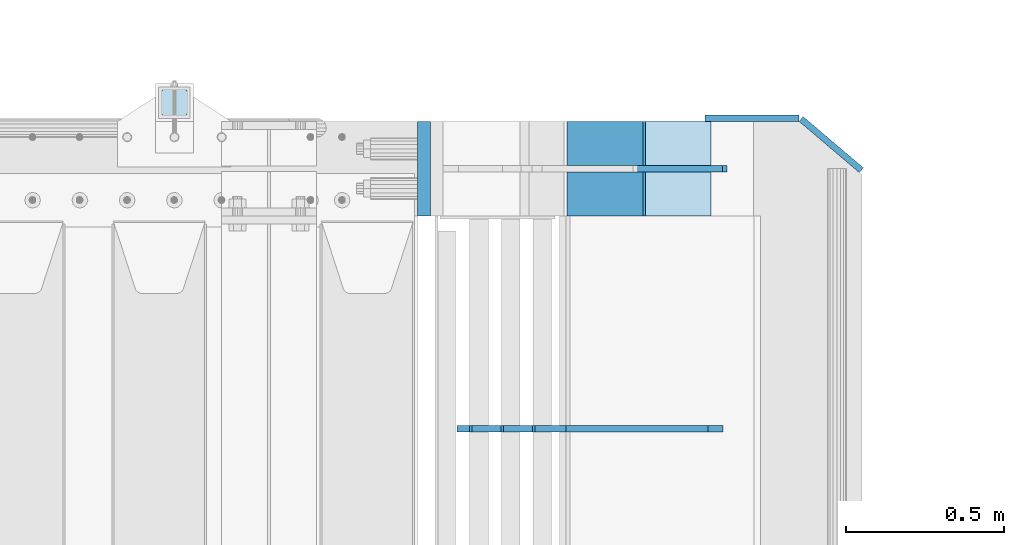
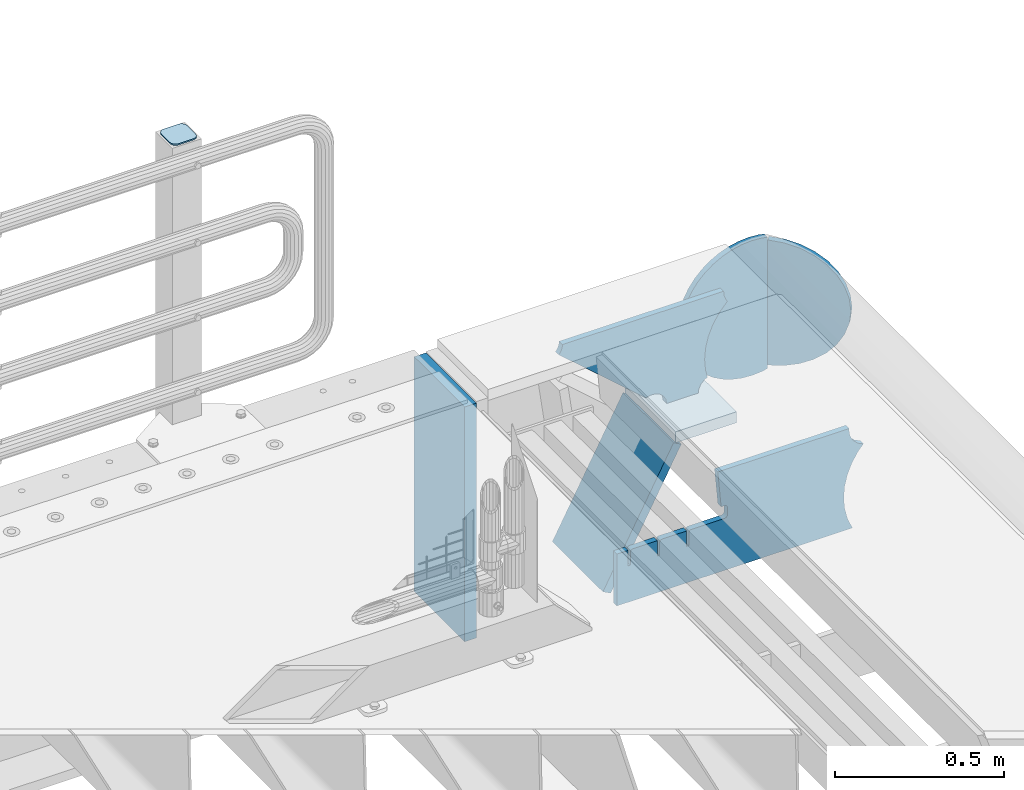
# One storey, part 227 of 242: 8 plates.
"""IFC2X3 building model written with IfcOpenShell, lengths in millimetres."""

from ifc_helpers import new_model, si_unit, frame, origin_with_axes, place, context, subcontext, project, spatial, faceted_brep, material, type_object, element, save


model = new_model("IFC2X3")

# Units and contexts
model_context = context("Model", 3, precision=1e-05, world=origin_with_axes())
body_context = subcontext(model_context, "Body", "Model", "MODEL_VIEW")
ifc_project = project(units=[si_unit("LENGTHUNIT", "METRE", prefix="MILLI"), si_unit("AREAUNIT", "SQUARE_METRE"), si_unit("VOLUMEUNIT", "CUBIC_METRE"), si_unit("MASSUNIT", "GRAM", prefix="KILO"), si_unit("TIMEUNIT", "SECOND"), si_unit("PLANEANGLEUNIT", "RADIAN"), si_unit("SOLIDANGLEUNIT", "STERADIAN"), si_unit("THERMODYNAMICTEMPERATUREUNIT", "DEGREE_CELSIUS"), si_unit("LUMINOUSINTENSITYUNIT", "LUMEN")], contexts=[model_context])

# Site, building, storey
site_placement = place(None, origin_with_axes())
site = spatial("IfcSite", under=ifc_project, at=site_placement, CompositionType="ELEMENT")
building_placement = place(site_placement, origin_with_axes())
building = spatial("IfcBuilding", under=site, at=building_placement, Name="Standard", CompositionType="ELEMENT")
storey_placement = place(building_placement, origin_with_axes())
storey = spatial("IfcBuildingStorey", under=building, at=storey_placement, Name="Undefined", CompositionType="ELEMENT", Elevation=0.0)

# Plates
ifc_material_1 = material(Name="STEEL/S355J2")
plate_type_1 = type_object("IfcPlateType", PredefinedType="NOTDEFINED")
plate_1_placement = place(storey_placement, frame((-22787.9999999999, -17833.9999999998, 1012.50000000001), z_axis=(0.0, 1.0, 0.0), x_axis=(-1.0, 0.0, 0.0)))
element("IfcPlate", 1, at=plate_1_placement, inside=storey, type_object=plate_type_1, material=ifc_material_1, context=body_context, shape_type="Brep", body=[
    faceted_brep([(0.0, -2.5, 19.0), (0.0, -2.5, 69.0), (0.0, 2.5, 69.0), (0.0, 2.5, 19.0), (0.476369668544066, -2.5, 73.2278977451715), (0.476369668544066, 2.5, 73.2278977451715), (1.88159150985302, -2.5, 77.2437910432345), (1.88159150985302, 2.5, 77.2437910432345), (4.14520183310742, -2.5, 80.8463062353148), (4.14520183310742, 2.5, 80.8463062353148), (7.15369376468516, -2.5, 83.8547981668926), (7.15369376468516, 2.5, 83.8547981668926), (10.7562089567655, -2.5, 86.118408490147), (10.7562089567655, 2.5, 86.118408490147), (14.7721022548285, -2.5, 87.5236303314559), (14.7721022548285, 2.5, 87.5236303314559), (19.0, -2.5, 88.0), (19.0, 2.5, 88.0), (69.0, -2.5, 88.0), (69.0, 2.5, 88.0), (73.2278977451715, -2.5, 87.5236303314559), (73.2278977451715, 2.5, 87.5236303314559), (77.2437910432345, -2.5, 86.118408490147), (77.2437910432345, 2.5, 86.118408490147), (80.8463062353148, -2.5, 83.8547981668926), (80.8463062353148, 2.5, 83.8547981668926), (83.8547981668926, -2.5, 80.8463062353148), (83.8547981668926, 2.5, 80.8463062353148), (86.118408490147, -2.5, 77.2437910432345), (86.118408490147, 2.5, 77.2437910432345), (87.5236303314559, -2.5, 73.2278977451715), (87.5236303314559, 2.5, 73.2278977451715), (88.0, -2.5, 69.0), (88.0, 2.5, 69.0), (88.0, -2.5, 19.0), (88.0, 2.5, 19.0), (87.5236303314559, -2.5, 14.7721022548285), (87.5236303314559, 2.5, 14.7721022548285), (86.118408490147, -2.5, 10.7562089567655), (86.118408490147, 2.5, 10.7562089567655), (83.8547981668926, -2.5, 7.15369376468516), (83.8547981668926, 2.5, 7.15369376468516), (80.8463062353148, -2.5, 4.14520183310742), (80.8463062353148, 2.5, 4.14520183310742), (77.2437910432345, -2.5, 1.88159150985302), (77.2437910432345, 2.5, 1.88159150985302), (73.2278977451715, -2.5, 0.476369668544066), (73.2278977451715, 2.5, 0.476369668544066), (69.0, -2.5, 0.0), (69.0, 2.5, 0.0), (19.0, -2.5, 0.0), (19.0, 2.5, 0.0), (14.7721022548285, -2.5, 0.476369668544066), (14.7721022548285, 2.5, 0.476369668544066), (10.7562089567655, -2.5, 1.88159150985302), (10.7562089567655, 2.5, 1.88159150985302), (7.15369376468516, -2.5, 4.14520183310742), (7.15369376468516, 2.5, 4.14520183310742), (4.14520183310742, -2.5, 7.15369376468516), (4.14520183310742, 2.5, 7.15369376468516), (1.88159150985302, -2.5, 10.7562089567655), (1.88159150985302, 2.5, 10.7562089567655), (0.476369668544066, -2.5, 14.7721022548285), (0.476369668544066, 2.5, 14.7721022548285)], [[[0, 1, 2, 3]], [[1, 4, 5, 2]], [[4, 6, 7, 5]], [[6, 8, 9, 7]], [[8, 10, 11, 9]], [[10, 12, 13, 11]], [[12, 14, 15, 13]], [[14, 16, 17, 15]], [[16, 18, 19, 17]], [[18, 20, 21, 19]], [[20, 22, 23, 21]], [[22, 24, 25, 23]], [[24, 26, 27, 25]], [[26, 28, 29, 27]], [[28, 30, 31, 29]], [[30, 32, 33, 31]], [[32, 34, 35, 33]], [[34, 36, 37, 35]], [[36, 38, 39, 37]], [[38, 40, 41, 39]], [[40, 42, 43, 41]], [[42, 44, 45, 43]], [[44, 46, 47, 45]], [[46, 48, 49, 47]], [[48, 50, 51, 49]], [[50, 52, 53, 51]], [[52, 54, 55, 53]], [[54, 56, 57, 55]], [[56, 58, 59, 57]], [[58, 60, 61, 59]], [[60, 62, 63, 61]], [[62, 0, 3, 63]], [[5, 7, 9, 11, 13, 15, 17, 19, 21, 23, 25, 27, 29, 31, 33, 35, 37, 39, 41, 43, 45, 47, 49, 51, 53, 55, 57, 59, 61, 63, 3, 2]], [[62, 60, 58, 56, 54, 52, 50, 48, 46, 44, 42, 40, 38, 36, 34, 32, 30, 28, 26, 24, 22, 20, 18, 16, 14, 12, 10, 8, 6, 4, 1, 0]]]),
])
ifc_material_2 = material(Name="STEEL/S355N")
plate_type_2 = type_object("IfcPlateType", PredefinedType="NOTDEFINED")
plate_2_placement = place(storey_placement, frame((-21338.0011701102, -18150.0000000008, -387.999999999302), z_axis=(1.0, 0.0, 0.0), x_axis=(0.0, 1.0, 0.0)))
element("IfcPlate", 2, at=plate_2_placement, inside=storey, type_object=plate_type_2, material=ifc_material_2, context=body_context, shape_type="Brep", body=[
    faceted_brep([(0.0, -20.0, 0.0), (3.31056071445346e-10, -20.0, 208.0), (3.31056071445346e-10, 20.0, 208.0), (0.0, 20.0, 0.0), (300.0, -20.0, 208.0), (300.0, 20.0, 208.0), (300.0, -20.0, 3.63797880709171e-12), (300.0, 20.0, 3.63797880709171e-12)], [[[0, 1, 2, 3]], [[1, 4, 5, 2]], [[4, 6, 7, 5]], [[6, 0, 3, 7]], [[5, 7, 3, 2]], [[6, 4, 1, 0]]]),
])
plate_type_3 = type_object("IfcPlateType", PredefinedType="NOTDEFINED")
plate_3_placement = place(storey_placement, frame((-21573.7531990434, -17849.999999999, -867.038754739308), z_axis=(0.469471552246176, 0.0, 0.882947598462992), x_axis=(0.0, -1.0, 0.0)))
element("IfcPlate", 3, at=plate_3_placement, inside=storey, type_object=plate_type_3, material=ifc_material_2, context=body_context, shape_type="Brep", body=[
    faceted_brep([(0.0, -15.0, 0.0), (0.0, -15.0000000000036, 515.0), (0.0, 15.0, 515.000000000002), (0.0, 15.0, 0.0), (300.0, -15.0000000000036, 515.0), (300.0, 15.0, 515.000000000002), (300.0, -15.0, 0.0), (300.0, 15.0, 0.0)], [[[0, 1, 2, 3]], [[1, 4, 5, 2]], [[4, 6, 7, 5]], [[6, 0, 3, 7]], [[5, 7, 3, 2]], [[6, 4, 1, 0]]]),
])
ifc_material_3 = material()
plate_type_4 = type_object("IfcPlateType", PredefinedType="NOTDEFINED")
plate_4_placement = place(storey_placement, frame((-22040.0, -17850.0, -875.0), z_axis=(0.0, 0.0, 1.0), x_axis=(0.0, -1.0, 0.0)))
element("IfcPlate", 4, at=plate_4_placement, inside=storey, type_object=plate_type_4, material=ifc_material_3, context=body_context, shape_type="Brep", body=[
    faceted_brep([(0.0, -20.0, 0.0), (9.5367431640625e-07, -20.0, 850.0), (9.5367431640625e-07, 20.0, 850.0), (0.0, 20.0, 0.0), (300.0, -20.0, 850.0), (300.0, 20.0, 850.0), (300.0, -20.0, 3.63797880709171e-12), (300.0, 20.0, 3.63797880709171e-12)], [[[0, 1, 2, 3]], [[1, 4, 5, 2]], [[4, 6, 7, 5]], [[6, 0, 3, 7]], [[5, 7, 3, 2]], [[6, 4, 1, 0]]]),
])
plate_type_5 = type_object("IfcPlateType", PredefinedType="NOTDEFINED")
plate_5_placement = place(storey_placement, frame((-21023.0011701102, -18000.0000000006, -29.9999999993023), z_axis=(-0.000446694000102124, 0.0, -0.99999990023223), x_axis=(-0.99999990023223, 0.0, 0.000446694000103734)))
element("IfcPlate", 5, at=plate_5_placement, inside=storey, type_object=plate_type_5, material=ifc_material_2, context=body_context, shape_type="Brep", body=[
    faceted_brep([(125.007775472979, 10.0, 291.842314882029), (131.755016800049, 10.0, 263.793234614468), (131.755016800049, -10.0, 263.793234614468), (125.007775472979, -10.0, 291.842314882029), (134.899927074479, 10.0, 224.060281342732), (134.899927074479, -10.0, 224.060281342732), (131.790514995217, 10.0, 184.324534302446), (131.790514995217, -10.0, 184.324534302446), (122.503344607205, 10.0, 145.564419461128), (122.503344607205, -10.0, 145.564419461128), (107.267096867741, 10.0, 108.734339483615), (107.267096867741, -10.0, 108.734339483615), (86.4569387623887, 10.0, 74.7411731709829), (86.4569387623887, -10.0, 74.7411731709829), (60.5852854486475, 10.0, 44.4219450946983), (60.5852854486475, -10.0, 44.4219450946983), (56.2519855253086, 10.0, 40.7176084148888), (56.2519855253086, -10.0, 40.7176084148888), (136.409234539125, -10.0, 297.721677540594), (147.386991180581, -10.0, 308.778803581017), (147.386991180581, 10.0, 308.778803581017), (136.409234539125, 10.0, 297.721677540594), (154.428166132755, -10.0, 322.678193223937), (154.428166132755, 10.0, 322.678193223937), (156.849001662973, -10.0, 338.070097995228), (156.849001662973, 10.0, 338.070097995228), (264.849004013293, -10.0, 338.118348049693), (264.849004013293, 10.0, 338.118348049693), (267.62876711955, -10.0, 321.701412969031), (267.62876711955, 10.0, 321.701412969031), (275.645118712175, -10.0, 307.107546191754), (275.645118712175, 10.0, 307.107546191754), (288.009068357209, -10.0, 295.955165748785), (288.009068357209, 10.0, 295.955165748785), (303.34948944753, -10.0, 289.481038692482), (303.34948944753, 10.0, 289.481038692482), (319.965173216922, -10.0, 288.403127172445), (319.965173216922, 10.0, 288.403127172445), (336.013487920231, -10.0, 292.840968489265), (336.013487920231, 10.0, 292.840968489265), (335.86907958984, -10.0, 293.150054931641), (335.86907958984, 10.0, 293.150054931641), (633.93705743644, -10.0, 32.8861672876964), (633.93705743644, 10.0, 32.8861672876964), (628.672097726398, -10.0, 25.6357574923157), (628.672097726398, 10.0, 25.6357574923157), (624.785781531267, -10.0, 17.5620477266101), (624.785781531267, 10.0, 17.5620477266101), (622.402919050597, -10.0, 8.92432757904925), (622.402919050597, 10.0, 8.92432757904925), (621.600036621094, -10.0, -8.74685213148041e-10), (621.600036621094, 10.0, -8.74685213148041e-10), (69.9999999999964, -10.0, -9.85096448857803e-11), (69.9999999999964, 10.0, -9.85096448857803e-11), (67.7728137216582, -10.0, 17.5170123094482), (67.7728137216582, 10.0, 17.5170123094482), (61.2329794213947, -10.0, 33.9193489203214), (61.2329794213947, 10.0, 33.9193489203214)], [[[0, 1, 2, 3]], [[4, 5, 2, 1]], [[6, 7, 5, 4]], [[8, 9, 7, 6]], [[10, 11, 9, 8]], [[12, 13, 11, 10]], [[14, 15, 13, 12]], [[16, 17, 15, 14]], [[18, 19, 20, 21]], [[19, 22, 23, 20]], [[22, 24, 25, 23]], [[24, 26, 27, 25]], [[26, 28, 29, 27]], [[28, 30, 31, 29]], [[30, 32, 33, 31]], [[32, 34, 35, 33]], [[34, 36, 37, 35]], [[36, 38, 39, 37]], [[38, 40, 41, 39]], [[40, 42, 43, 41]], [[42, 44, 45, 43]], [[44, 46, 47, 45]], [[46, 48, 49, 47]], [[48, 50, 51, 49]], [[50, 52, 53, 51]], [[52, 54, 55, 53]], [[54, 56, 57, 55]], [[12, 10, 8, 6, 4, 1, 0, 21, 20, 23, 25, 27, 29, 31, 33, 35, 37, 39, 41, 43, 45, 47, 49, 51, 53, 55, 57, 16, 14]], [[18, 21, 0, 3]], [[56, 54, 52, 50, 48, 46, 44, 42, 40, 38, 36, 34, 32, 30, 28, 26, 24, 22, 19, 18, 3, 2, 5, 7, 9, 11, 13, 15, 17]], [[57, 56, 17, 16]]]),
])
plate_type_6 = type_object("IfcPlateType", PredefinedType="NOTDEFINED")
plate_6_placement = place(storey_placement, frame((-21094.0817660324, -18825.0007171631, -374.002067436516), z_axis=(0.0, 0.0, 1.0), x_axis=(-1.0, 0.0, 0.0)))
element("IfcPlate", 6, at=plate_6_placement, inside=storey, type_object=plate_type_6, material=ifc_material_2, context=body_context, shape_type="Brep", body=[
    faceted_brep([(801.919404066546, -10.0, 188.0), (801.919404066546, 10.0, 188.0), (801.919404066546, 10.0, 132.002067436952), (801.919404066546, -10.0, 132.002067436952), (793.919404066546, 10.0, 132.002067436952), (793.919404066546, -10.0, 132.002067436952), (793.919404066546, 10.0, 180.002067436952), (793.919404066546, -10.0, 180.002067436952), (793.527856196906, 10.0, 182.474203391951), (793.527856196906, -10.0, 182.474203391951), (792.391540021545, 10.0, 184.704349455291), (792.391540021545, -10.0, 184.704349455291), (790.621686084887, 10.0, 186.474203391951), (790.621686084887, -10.0, 186.474203391951), (788.391540021545, 10.0, 187.610519567313), (788.391540021545, -10.0, 187.610519567313), (785.919404066546, -10.0, 188.002067436952), (785.919404066546, 10.0, 188.0), (841.0, -10.0, 188.0), (841.0, -10.0, 0.0), (841.0, 10.0, 0.0), (841.0, 10.0, 188.0), (33.3619566735979, -10.0, 0.0), (33.3619566735979, 10.0, 0.0), (36.2350612208174, -10.0, 4.68848050267007), (36.2350612208174, 10.0, 4.68848050267007), (51.4877592159428, -10.0, 41.5117508652783), (51.4877592159428, 10.0, 41.5117508652783), (60.792242588137, -10.0, 80.2677133162963), (60.792242588137, 10.0, 80.2677133162963), (63.9194040769726, -10.0, 120.002067436515), (63.9194040769726, 10.0, 120.002067436515), (60.792242588137, -10.0, 159.736421556734), (60.792242588137, 10.0, 159.736421556734), (51.4877592159428, -10.0, 198.492384007752), (51.4877592159428, 10.0, 198.492384007752), (36.2350612208174, -10.0, 235.31565437036), (36.2350612208174, 10.0, 235.31565437036), (15.4097206482074, -10.0, 269.299521518803), (15.4097206482074, 10.0, 269.299521518803), (-3.35474438098754, -10.0, 291.269887256574), (-3.35474438098754, 10.0, 291.269887256574), (-2.36881039375294, -10.0, 291.426043859339), (-2.36881039375294, 10.0, 291.426043859339), (17.1449676604716, -10.0, 301.368810393754), (17.1449676604716, 10.0, 301.368810393754), (32.6311896062471, -10.0, 316.855032339527), (32.6311896062471, 10.0, 316.855032339527), (42.573956140659, -10.0, 336.368810393754), (42.573956140659, 10.0, 336.368810393754), (46.0, -10.0, 358.0), (46.0, 10.0, 358.0), (45.0495205499137, -10.0, 364.001091067617), (45.0495205499137, 10.0, 364.001091067617), (495.040008544922, -10.0, 364.010009765625), (495.040008544922, 10.0, 364.010009765625), (483.600036621094, -10.0, 233.759994506836), (483.600036621094, 10.0, 233.759994506836), (472.0, -10.0, 233.759994506836), (472.0, 10.0, 233.759994506836), (468.909830056251, -10.0, 233.270559669787), (468.909830056251, 10.0, 233.270559669787), (466.122147477075, -10.0, 231.850164450585), (466.122147477075, 10.0, 231.850164450585), (463.909830056251, -10.0, 229.637847029761), (463.909830056251, 10.0, 229.637847029761), (462.489434837047, -10.0, 226.850164450585), (462.489434837047, 10.0, 226.850164450585), (462.0, -10.0, 223.759994506836), (462.0, 10.0, 223.759994506836), (462.0, -10.0, 198.0), (462.0, 10.0, 198.0), (462.489434837047, -10.0, 194.909830056251), (462.489434837047, 10.0, 194.909830056251), (463.909830056251, -10.0, 192.122147477075), (463.909830056251, 10.0, 192.122147477075), (466.122147477075, -10.0, 189.909830056251), (466.122147477075, 10.0, 189.909830056251), (468.909830056251, -10.0, 188.489434837048), (468.909830056251, 10.0, 188.489434837048), (472.0, -10.0, 188.0), (472.0, 10.0, 188.0), (585.919404066546, -10.0, 188.002067436952), (585.919404066546, 10.0, 188.0), (588.391540021545, -10.0, 187.610519567313), (588.391540021545, 10.0, 187.610519567313), (590.621686084887, -10.0, 186.474203391951), (590.621686084887, 10.0, 186.474203391951), (592.391540021545, -10.0, 184.704349455291), (592.391540021545, 10.0, 184.704349455291), (593.527856196906, -10.0, 182.474203391951), (593.527856196906, 10.0, 182.474203391951), (593.919404066546, -10.0, 180.002067436952), (593.919404066546, 10.0, 180.002067436952), (593.919404066546, -10.0000000000036, 132.002067436952), (593.919404066546, 10.0, 132.002067436952), (601.919404066546, -10.0000000000036, 132.002067436952), (601.919404066546, 10.0, 132.002067436952), (601.919404066546, -10.0, 188.0), (601.919404066546, 10.0, 188.0), (685.919404066546, -10.0, 188.002067436952), (685.919404066546, 10.0, 188.0), (688.391540021545, -10.0, 187.610519567313), (688.391540021545, 10.0, 187.610519567313), (690.621686084887, -10.0, 186.474203391951), (690.621686084887, 10.0, 186.474203391951), (692.391540021545, -10.0, 184.704349455291), (692.391540021545, 10.0, 184.704349455291), (693.527856196906, -10.0, 182.474203391951), (693.527856196906, 10.0, 182.474203391951), (693.919404066546, -10.0, 180.002067436952), (693.919404066546, 10.0, 180.002067436952), (693.919404066546, -10.0, 132.002067436952), (693.919404066546, 10.0, 132.002067436952), (701.919404066546, -10.0, 132.002067436952), (701.919404066546, 10.0, 132.002067436952), (701.919404066546, -10.0, 188.0), (701.919404066546, 10.0, 188.0)], [[[0, 1, 2, 3]], [[3, 2, 4, 5]], [[5, 4, 6, 7]], [[7, 6, 8, 9]], [[9, 8, 10, 11]], [[11, 10, 12, 13]], [[13, 12, 14, 15]], [[16, 15, 14, 17]], [[18, 19, 20, 21]], [[20, 19, 22, 23]], [[22, 24, 25, 23]], [[26, 27, 25, 24]], [[28, 29, 27, 26]], [[30, 31, 29, 28]], [[32, 33, 31, 30]], [[34, 35, 33, 32]], [[36, 37, 35, 34]], [[38, 39, 37, 36]], [[39, 38, 40, 41]], [[40, 42, 43, 41]], [[44, 45, 43, 42]], [[46, 47, 45, 44]], [[48, 49, 47, 46]], [[50, 51, 49, 48]], [[52, 53, 51, 50]], [[54, 55, 53, 52]], [[54, 56, 57, 55]], [[56, 58, 59, 57]], [[58, 60, 61, 59]], [[60, 62, 63, 61]], [[62, 64, 65, 63]], [[64, 66, 67, 65]], [[66, 68, 69, 67]], [[68, 70, 71, 69]], [[70, 72, 73, 71]], [[72, 74, 75, 73]], [[74, 76, 77, 75]], [[76, 78, 79, 77]], [[78, 80, 81, 79]], [[81, 80, 82, 83]], [[82, 84, 85, 83]], [[86, 87, 85, 84]], [[88, 89, 87, 86]], [[90, 91, 89, 88]], [[92, 93, 91, 90]], [[94, 95, 93, 92]], [[96, 97, 95, 94]], [[98, 99, 97, 96]], [[99, 98, 100, 101]], [[100, 102, 103, 101]], [[104, 105, 103, 102]], [[106, 107, 105, 104]], [[108, 109, 107, 106]], [[110, 111, 109, 108]], [[112, 113, 111, 110]], [[114, 115, 113, 112]], [[116, 117, 115, 114]], [[117, 116, 16, 17]], [[12, 10, 8, 6, 4, 2, 1, 21, 20, 23, 25, 27, 29, 31, 33, 35, 37, 39, 41, 43, 45, 47, 49, 51, 53, 55, 57, 59, 61, 63, 65, 67, 69, 71, 73, 75, 77, 79, 81, 83, 85, 87, 89, 91, 93, 95, 97, 99, 101, 103, 105, 107, 109, 111, 113, 115, 117, 17, 14]], [[18, 21, 1, 0]], [[116, 114, 112, 110, 108, 106, 104, 102, 100, 98, 96, 94, 92, 90, 88, 86, 84, 82, 80, 78, 76, 74, 72, 70, 68, 66, 64, 62, 60, 58, 56, 54, 52, 50, 48, 46, 44, 42, 40, 38, 36, 34, 32, 30, 28, 26, 24, 22, 19, 18, 0, 3, 5, 7, 9, 11, 13, 15, 16]]]),
])
plate_type_7 = type_object("IfcPlateType", PredefinedType="NOTDEFINED")
plate_7_placement = place(storey_placement, frame((-20660.0011701094, -17840.0, -498.000000000001), z_axis=(0.0, 0.0, 1.0), x_axis=(-1.0, 0.0, 0.0)))
element("IfcPlate", 7, at=plate_7_placement, inside=storey, type_object=plate_type_7, material=ifc_material_2, context=body_context, shape_type="Brep", body=[
    faceted_brep([(244.0, -10.0, 0.0), (209.275179461318, -10.0, 2.48356818105242), (209.275179461318, 10.0, 2.48356818105242), (244.0, 10.0, 0.0), (278.724820538682, -10.0, 2.48356818105236), (278.724820538682, 10.0, 2.48356818105236), (312.742743869308, -10.0, 9.88371443806261), (312.742743869308, 10.0, 9.88371443806261), (345.361263172461, -10.0, 22.0497931334975), (345.361263172461, 10.0, 22.0497931334975), (375.916359459166, -10.0, 38.7341379891918), (375.916359459166, 10.0, 38.7341379891918), (403.78601908265, -10.0, 59.597103857561), (403.78601908265, 10.0, 59.597103857561), (428.402896142437, -10.0, 84.2139809173505), (428.402896142437, 10.0, 84.2139809173505), (449.265862010809, -10.0, 112.083640540834), (449.265862010809, 10.0, 112.083640540834), (465.950206866502, -10.0, 142.63873682754), (465.950206866502, 10.0, 142.63873682754), (478.116285561937, -10.0, 175.257256130691), (478.116285561937, 10.0, 175.257256130691), (485.516431818949, -10.0, 209.275179461318), (485.516431818949, 10.0, 209.275179461318), (488.0, -10.0, 244.0), (488.0, 10.0, 244.0), (485.516431818949, -10.0, 278.724820538682), (485.516431818949, 10.0, 278.724820538682), (478.116285561937, -10.0, 312.742743869309), (478.116285561937, 10.0, 312.742743869309), (465.950206866502, -10.0, 345.36126317246), (465.950206866502, 10.0, 345.36126317246), (449.265862010809, -10.0, 375.916359459166), (449.265862010809, 10.0, 375.916359459166), (428.402896142437, -10.0, 403.78601908265), (428.402896142437, 10.0, 403.78601908265), (403.78601908265, -10.0, 428.402896142439), (403.78601908265, 10.0, 428.402896142439), (375.916359459166, -10.0, 449.265862010808), (375.916359459166, 10.0, 449.265862010808), (345.361263172461, -10.0, 465.950206866503), (345.361263172461, 10.0, 465.950206866503), (312.742743869308, -10.0, 478.116285561937), (312.742743869308, 10.0, 478.116285561937), (278.724820538682, -10.0, 485.516431818948), (278.724820538682, 10.0, 485.516431818948), (244.0, -10.0, 488.0), (244.0, 10.0, 488.0), (209.275179461318, -10.0, 485.516431818948), (209.275179461318, 10.0, 485.516431818948), (190.05541508122, -10.0, 481.335427997649), (190.05854791337, -10.0, 6.66389049643203), (190.053997906718, 10.0, 6.66488028979381), (190.050865087633, 10.0, 481.334438207129)], [[[0, 1, 2, 3]], [[4, 0, 3, 5]], [[6, 4, 5, 7]], [[8, 6, 7, 9]], [[10, 8, 9, 11]], [[12, 10, 11, 13]], [[14, 12, 13, 15]], [[16, 14, 15, 17]], [[18, 16, 17, 19]], [[20, 18, 19, 21]], [[22, 20, 21, 23]], [[24, 22, 23, 25]], [[26, 24, 25, 27]], [[28, 26, 27, 29]], [[30, 28, 29, 31]], [[32, 30, 31, 33]], [[34, 32, 33, 35]], [[36, 34, 35, 37]], [[38, 36, 37, 39]], [[40, 38, 39, 41]], [[42, 40, 41, 43]], [[44, 42, 43, 45]], [[46, 44, 45, 47]], [[48, 46, 47, 49]], [[1, 0, 4, 6, 8, 10, 12, 14, 16, 18, 20, 22, 24, 26, 28, 30, 32, 34, 36, 38, 40, 42, 44, 46, 48, 50, 51]], [[2, 1, 51, 52]], [[49, 47, 45, 43, 41, 39, 37, 35, 33, 31, 29, 27, 25, 23, 21, 19, 17, 15, 13, 11, 9, 7, 5, 3, 2, 52, 53]], [[48, 49, 53, 50]], [[52, 51, 50, 53]]]),
])
plate_type_8 = type_object("IfcPlateType", PredefinedType="NOTDEFINED")
plate_8_placement = place(storey_placement, frame((-20806.3319447428, -17874.0468507943, -30.6119535183306), z_axis=(-0.0673151699806107, 0.0572188599835183, -0.996089689713064), x_axis=(-0.758954680570056, 0.64512205263455, 0.0883477789499519)))
element("IfcPlate", 8, at=plate_8_placement, inside=storey, type_object=plate_type_8, material=ifc_material_2, context=body_context, shape_type="Brep", body=[
    faceted_brep([(0.0, -10.0, 0.0), (-48.0501251221649, -10.0, 8.67006015777611), (-48.0501251221667, 10.0, 8.67006015777599), (0.0, 10.0, 0.0), (-93.1325836184478, -10.0000000000036, 25.6772422790529), (-93.1325836184496, 10.0, 25.6772422790528), (-133.519607544504, -10.0, 50.3672103881838), (-133.519607544502, 10.0, 50.3672103881837), (-167.654617310473, -9.99999999999636, 81.7923126220704), (-167.654617310474, 10.0, 81.7923126220705), (-194.116653443695, -10.0, 118.75399017334), (-194.116653443695, 10.0, 118.75399017334), (-212.219375612117, -10.0, 159.802307128906), (-212.219375612117, 10.0000000000036, 159.802307128906), (-220.93566894756, -10.0000000000036, 203.390228271484), (-220.93566894756, 9.99999999999636, 203.390228271484), (-220.042388918751, -10.0, 247.831420898438), (-220.042388918753, 10.0, 247.831420898438), (-209.448760989545, -10.0, 291.430206298828), (-209.448760989545, 10.0, 291.430206298829), (-189.931198123787, -10.0, 332.477691650391), (-189.931198123787, 10.0, 332.477691650391), (-161.872329715989, -10.0, 369.429595947266), (-161.87232971599, 10.0, 369.429595947266), (-126.47386169876, -10.0000000000036, 400.854248046875), (-126.473861698762, 9.99999999999636, 400.854248046875), (-85.0954742478607, -9.99999999999636, 425.544403076172), (-85.0954742478607, 10.0000000000036, 425.544403076172), (-39.3266487170413, -9.99999999999636, 442.551971435547), (-39.3266487170431, 10.0, 442.551971435547), (9.0716190288349, -10.0, 451.221954345703), (9.07161902883308, 10.0, 451.221954345703), (49.1691665649414, -10.0, 5.16138243256137e-11), (49.1691665649414, 10.0000000000036, 5.15569809067529e-11)], [[[0, 1, 2, 3]], [[1, 4, 5, 2]], [[4, 6, 7, 5]], [[6, 8, 9, 7]], [[8, 10, 11, 9]], [[10, 12, 13, 11]], [[12, 14, 15, 13]], [[14, 16, 17, 15]], [[16, 18, 19, 17]], [[18, 20, 21, 19]], [[20, 22, 23, 21]], [[22, 24, 25, 23]], [[24, 26, 27, 25]], [[26, 28, 29, 27]], [[28, 30, 31, 29]], [[30, 32, 33, 31]], [[32, 0, 3, 33]], [[5, 7, 9, 11, 13, 15, 17, 19, 21, 23, 25, 27, 29, 31, 33, 3, 2]], [[32, 30, 28, 26, 24, 22, 20, 18, 16, 14, 12, 10, 8, 6, 4, 1, 0]]]),
])

save(model, "model.ifc")
